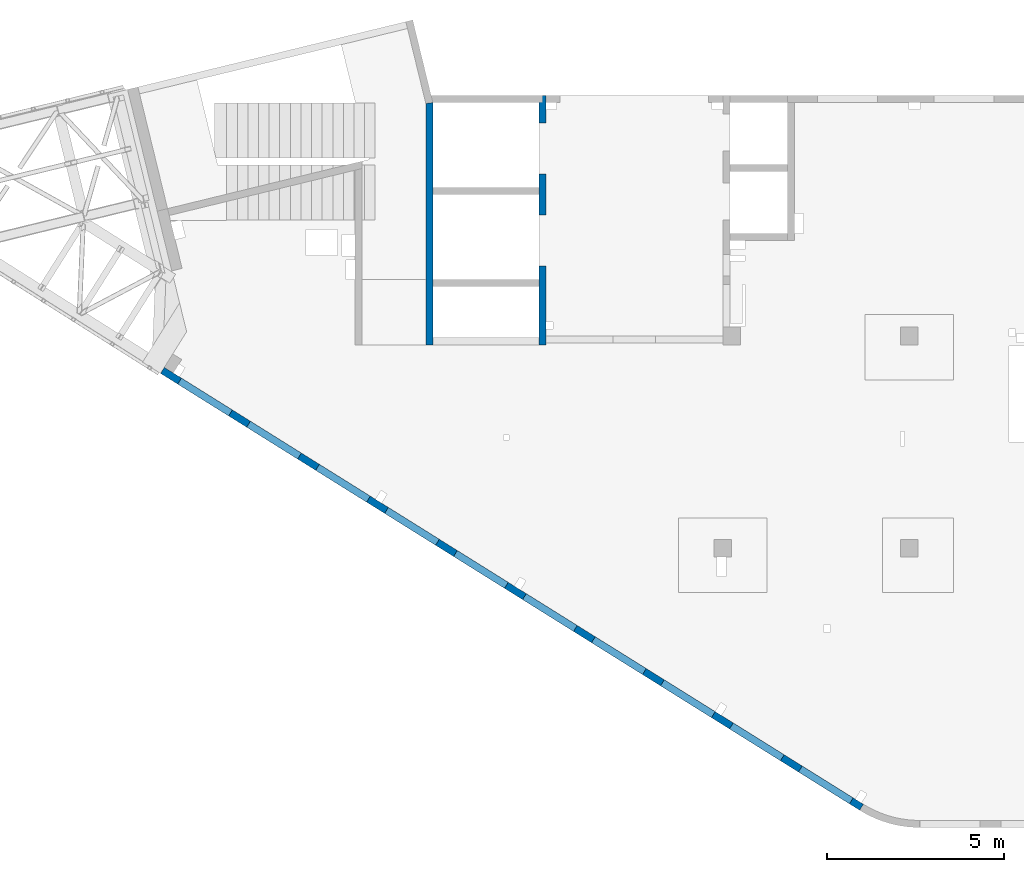
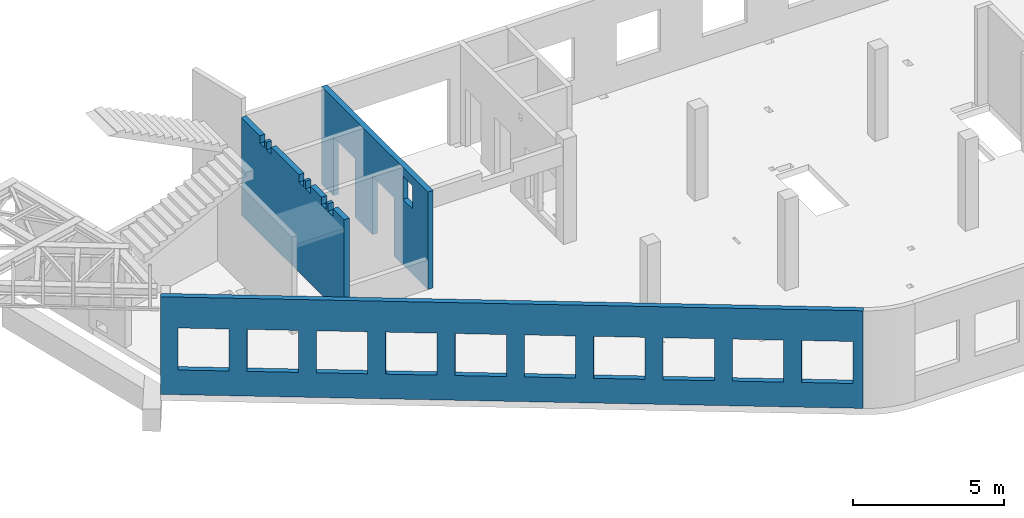
# One storey, part 64 of 66: 3 walls, 19 openings.
"""IFC4 building model written with IfcOpenShell, lengths in millimetres."""

from ifc_helpers import new_model, entity, si_unit, converted_unit, derived_unit, direction, frame, origin, place, context, subcontext, project, spatial, indexed_curve, outline, extrude, polygons, material, type_object, element, save


model = new_model("IFC4")

# Units and contexts
model_context = context("Model", 3, precision=0.01, world=origin(), true_north=direction((6.12303176911189e-17, 1.0)))
plan_context = context("Plan", 3, precision=0.01, world=origin(), true_north=direction((6.12303176911189e-17, 1.0)))
body_context = subcontext(model_context, "Body", "Model", "MODEL_VIEW")
ifc_project = project(units=[si_unit("LENGTHUNIT", "METRE", prefix="MILLI"), si_unit("AREAUNIT", "SQUARE_METRE"), si_unit("VOLUMEUNIT", "CUBIC_METRE"), converted_unit("PLANEANGLEUNIT", "DEGREE", entity("IfcRatioMeasure", 0.0174532925199433), si_unit("PLANEANGLEUNIT", "RADIAN"), dimensions=[0, 0, 0, 0, 0, 0, 0]), si_unit("MASSUNIT", "GRAM", prefix="KILO"), derived_unit("MASSDENSITYUNIT", [(si_unit("MASSUNIT", "GRAM", prefix="KILO"), 1), (si_unit("LENGTHUNIT", "METRE"), -3)]), derived_unit("MOMENTOFINERTIAUNIT", [(si_unit("LENGTHUNIT", "METRE"), 4)]), si_unit("TIMEUNIT", "SECOND"), si_unit("FREQUENCYUNIT", "HERTZ"), si_unit("THERMODYNAMICTEMPERATUREUNIT", "DEGREE_CELSIUS"), derived_unit("THERMALTRANSMITTANCEUNIT", [(si_unit("MASSUNIT", "GRAM", prefix="KILO"), 1), (si_unit("THERMODYNAMICTEMPERATUREUNIT", "KELVIN"), -1), (si_unit("TIMEUNIT", "SECOND"), -3)]), derived_unit("VOLUMETRICFLOWRATEUNIT", [(si_unit("LENGTHUNIT", "METRE"), 3), (si_unit("TIMEUNIT", "SECOND"), -1)]), derived_unit("MASSFLOWRATEUNIT", [(si_unit("MASSUNIT", "GRAM", prefix="KILO"), 1), (si_unit("TIMEUNIT", "SECOND"), -1)]), derived_unit("ROTATIONALFREQUENCYUNIT", [(si_unit("TIMEUNIT", "SECOND"), -1)]), si_unit("ELECTRICCURRENTUNIT", "AMPERE"), si_unit("ELECTRICVOLTAGEUNIT", "VOLT"), si_unit("POWERUNIT", "WATT"), si_unit("FORCEUNIT", "NEWTON", prefix="KILO"), si_unit("ILLUMINANCEUNIT", "LUX"), si_unit("LUMINOUSFLUXUNIT", "LUMEN"), si_unit("LUMINOUSINTENSITYUNIT", "CANDELA"), derived_unit("USERDEFINED", [(si_unit("MASSUNIT", "GRAM", prefix="KILO"), -1), (si_unit("LENGTHUNIT", "METRE"), -2), (si_unit("TIMEUNIT", "SECOND"), 3), (si_unit("LUMINOUSFLUXUNIT", "LUMEN"), 1)]), derived_unit("LINEARVELOCITYUNIT", [(si_unit("LENGTHUNIT", "METRE"), 1), (si_unit("TIMEUNIT", "SECOND"), -1)]), si_unit("PRESSUREUNIT", "PASCAL"), derived_unit("USERDEFINED", [(si_unit("LENGTHUNIT", "METRE"), -2), (si_unit("MASSUNIT", "GRAM", prefix="KILO"), 1), (si_unit("TIMEUNIT", "SECOND"), -2)]), derived_unit("LINEARFORCEUNIT", [(si_unit("MASSUNIT", "GRAM", prefix="KILO"), 1), (si_unit("LENGTHUNIT", "METRE"), 1), (si_unit("TIMEUNIT", "SECOND"), -2), (si_unit("LENGTHUNIT", "METRE"), -1)]), derived_unit("PLANARFORCEUNIT", [(si_unit("MASSUNIT", "GRAM", prefix="KILO"), 1), (si_unit("LENGTHUNIT", "METRE"), 1), (si_unit("TIMEUNIT", "SECOND"), -2), (si_unit("LENGTHUNIT", "METRE"), -2)])], contexts=[model_context, plan_context])

# Site, building, storey
site_placement = place(None, origin())
site = spatial("IfcSite", under=ifc_project, at=site_placement, CompositionType="ELEMENT")
building_placement = place(site_placement, origin())
building = spatial("IfcBuilding", under=site, at=building_placement, CompositionType="ELEMENT")
storey_placement = place(building_placement, frame((0.0, 0.0, 19800.0)))
storey = spatial("IfcBuildingStorey", under=building, at=storey_placement, Name="06", CompositionType="ELEMENT", Elevation=19800.0)

# Wall, openings
ifc_material = material()
wall_type = type_object("IfcWallType", Name=":ADSK_ 25_200", PredefinedType="STANDARD")
wall_1_placement = place(storey_placement, frame((19822.35, 371.16, -150.0), z_axis=(0.0, 0.0, 1.0), x_axis=(-0.848052743777574, 0.529911826412025, 0.0)))
wall_1 = element("IfcWall", 1, at=wall_1_placement, inside=storey, type_object=wall_type, material=ifc_material, Name=":ADSK_ 25_200", ObjectType=":ADSK_ 25_200", PredefinedType="NOTDEFINED", context=body_context, shape_type="Tessellation", body=[
    polygons([(9.13669140345519e-13, -100.0, 0.0), (23011.6394501553, -99.9999999999989, 0.0), (23311.6394501553, -100.000000000001, 0.0), (23311.6394501553, -100.000000000001, 3950.0), (23011.6394501553, -99.9999999999989, 3950.0), (9.13669140345519e-13, -100.0, 3950.0), (21041.6390317217, -100.0, 2700.0), (22741.6390317217, -99.9999999999989, 2700.0), (22741.6390317217, -99.9999999999989, 1000.00000000001), (21041.6390317217, -100.0, 1000.00000000001), (18741.6390317217, -99.9999999999989, 2700.0), (20441.6390317217, -100.000000000001, 2700.0), (20441.6390317217, -100.000000000001, 1000.00000000001), (18741.6390317217, -99.9999999999989, 1000.00000000001), (16441.6390317217, -100.000000000001, 2700.0), (18141.6390317217, -100.000000000001, 2700.0), (18141.6390317217, -100.000000000001, 1000.00000000001), (16441.6390317217, -100.000000000001, 1000.00000000001), (14141.6390317217, -100.0, 2700.0), (15841.6390317217, -100.0, 2700.0), (15841.6390317217, -100.0, 1000.00000000001), (14141.6390317217, -100.0, 1000.00000000001), (11841.6390317217, -99.9999999999989, 2700.0), (13541.6390317217, -100.000000000001, 2700.0), (13541.6390317217, -100.000000000001, 1000.00000000001), (11841.6390317217, -99.9999999999989, 1000.00000000001), (9541.63903172168, -100.000000000001, 2700.0), (11241.6390317217, -100.0, 2700.0), (11241.6390317217, -100.0, 1000.00000000001), (9541.63903172168, -100.000000000001, 1000.00000000001), (7241.63903172167, -99.9999999999995, 2700.0), (8941.63903172167, -99.9999999999995, 2700.0), (8941.63903172167, -99.9999999999995, 1000.00000000001), (7241.63903172167, -99.9999999999995, 1000.00000000001), (4941.63903172166, -99.9999999999989, 2700.0), (6641.63903172166, -99.9999999999989, 2700.0), (6641.63903172166, -99.9999999999989, 1000.00000000001), (4941.63903172166, -99.9999999999989, 1000.00000000001), (2641.63903172165, -100.0, 2700.0), (4341.63903172165, -100.0, 2700.0), (4341.63903172165, -100.0, 1000.00000000001), (2641.63903172165, -100.0, 1000.00000000001), (341.639031721648, -100.000000000002, 2700.0), (2041.63903172165, -100.0, 2700.0), (2041.63903172165, -100.0, 1000.00000000001), (341.639031721648, -100.000000000002, 1000.00000000001), (22741.6390317217, 100.000000000319, 2700.0), (21041.6390317217, 100.000000000321, 2700.0), (21041.6390317217, 100.000000000321, 1000.00000000001), (22741.6390317217, 100.000000000319, 1000.00000000001), (20441.6390317217, 100.000000000319, 2700.0), (18741.6390317217, 100.000000000322, 2700.0), (18741.6390317217, 100.000000000322, 1000.00000000001), (20441.6390317217, 100.000000000319, 1000.00000000001), (18141.6390317217, 100.000000000318, 2700.0), (16441.6390317217, 100.000000000319, 2700.0), (16441.6390317217, 100.000000000319, 1000.00000000001), (18141.6390317217, 100.000000000318, 1000.00000000001), (15841.6390317217, 100.000000000321, 2700.0), (14141.6390317217, 100.000000000322, 2700.0), (14141.6390317217, 100.000000000322, 1000.00000000001), (15841.6390317217, 100.000000000321, 1000.00000000001), (13541.6390317217, 100.000000000319, 2700.0), (11841.6390317217, 100.000000000321, 2700.0), (11841.6390317217, 100.000000000321, 1000.00000000001), (13541.6390317217, 100.000000000319, 1000.00000000001), (11241.6390317217, 100.000000000321, 2700.0), (9541.63903172168, 100.000000000319, 2700.0), (9541.63903172168, 100.000000000319, 1000.00000000001), (11241.6390317217, 100.000000000321, 1000.00000000001), (8941.63903172167, 100.000000000319, 2700.0), (7241.63903172167, 100.000000000321, 2700.0), (7241.63903172167, 100.000000000321, 1000.00000000001), (8941.63903172167, 100.000000000319, 1000.00000000001), (6641.63903172167, 100.000000000322, 2700.0), (4941.63903172166, 100.000000000322, 2700.0), (4941.63903172166, 100.000000000322, 1000.00000000001), (6641.63903172166, 100.000000000322, 1000.00000000001), (4341.63903172166, 100.000000000321, 2700.0), (2641.63903172165, 100.000000000319, 2700.0), (2641.63903172165, 100.000000000319, 1000.00000000001), (4341.63903172166, 100.000000000321, 1000.00000000001), (2041.63903172165, 100.000000000321, 2700.0), (341.639031721653, 100.000000000321, 2700.0), (341.639031721653, 100.00000000032, 1000.00000000001), (2041.63903172165, 100.000000000321, 1000.00000000001), (1.18438592267012e-13, 100.000000000001, 0.0), (1.18438592267012e-13, 100.000000000001, 3950.0), (23311.6394501553, 100.000000000001, 3950.0), (23311.6394501553, 100.000000000001, 0.0)], [[[1, 2, 3, 4, 5, 6], [7, 8, 9, 10], [11, 12, 13, 14], [15, 16, 17, 18], [19, 20, 21, 22], [23, 24, 25, 26], [27, 28, 29, 30], [31, 32, 33, 34], [35, 36, 37, 38], [39, 40, 41, 42], [43, 44, 45, 46]], [[87, 88, 89, 90], [47, 48, 49, 50], [51, 52, 53, 54], [55, 56, 57, 58], [59, 60, 61, 62], [63, 64, 65, 66], [67, 68, 69, 70], [71, 72, 73, 74], [75, 76, 77, 78], [79, 80, 81, 82], [83, 84, 85, 86]], [[3, 2, 1, 87, 90]], [[6, 5, 4, 89, 88]], [[1, 6, 88, 87]], [[4, 3, 90, 89]], [[48, 47, 8, 7]], [[48, 7, 10, 49]], [[49, 10, 9, 50]], [[8, 47, 50, 9]], [[52, 51, 12, 11]], [[52, 11, 14, 53]], [[53, 14, 13, 54]], [[12, 51, 54, 13]], [[56, 55, 16, 15]], [[56, 15, 18, 57]], [[57, 18, 17, 58]], [[16, 55, 58, 17]], [[60, 59, 20, 19]], [[60, 19, 22, 61]], [[61, 22, 21, 62]], [[20, 59, 62, 21]], [[64, 63, 24, 23]], [[64, 23, 26, 65]], [[65, 26, 25, 66]], [[24, 63, 66, 25]], [[68, 67, 28, 27]], [[68, 27, 30, 69]], [[69, 30, 29, 70]], [[28, 67, 70, 29]], [[72, 71, 32, 31]], [[72, 31, 34, 73]], [[73, 34, 33, 74]], [[32, 71, 74, 33]], [[76, 75, 36, 35]], [[76, 35, 38, 77]], [[77, 38, 37, 78]], [[36, 75, 78, 37]], [[80, 79, 40, 39]], [[80, 39, 42, 81]], [[81, 42, 41, 82]], [[40, 79, 82, 41]], [[84, 83, 44, 43]], [[84, 43, 46, 85]], [[85, 46, 45, 86]], [[44, 83, 86, 45]]], closed=True),
])
placement_1 = place(wall_1_placement, frame((16613.72, 10818.86, 150.0), z_axis=(0.0, 0.0, 1.0), x_axis=(-0.848052743777574, -0.529911826412026, 0.0)))
element("IfcOpeningElement", 2, at=placement_1, cuts=wall_1, Name=":ADSK_ 25_200", PredefinedType="OPENING", context=body_context, shape_type="SweptSolid", body=[
    extrude(outline(indexed_curve([(-849.999999999993, -850.0), (849.999999999993, -850.0), (849.999999999993, 850.0), (-849.999999999993, 850.0), (-849.999999999993, -850.0)], self_intersect=False)), frame((1310.08, 12056.6, 1700.0), z_axis=(-0.529911826412026, -0.848052743777574, 0.0), x_axis=(0.0, 0.0, -1.0)), (0.0, 0.0, 1.0), 200.000000000959),
])
element("IfcOpeningElement", 3, at=placement_1, cuts=wall_1, Name=":ADSK_ 25_200", PredefinedType="OPENING", context=body_context, shape_type="SweptSolid", body=[
    extrude(outline(indexed_curve([(-849.999999999993, -850.0), (849.999999999993, -850.0), (849.999999999993, 850.0), (-849.999999999993, 850.0), (-849.999999999993, -850.0)], self_intersect=False)), frame((3260.6, 10837.81, 1700.0), z_axis=(-0.529911826412026, -0.848052743777574, 0.0), x_axis=(0.0, 0.0, -1.0)), (0.0, 0.0, 1.0), 200.000000000962),
])
element("IfcOpeningElement", 4, at=placement_1, cuts=wall_1, Name=":ADSK_ 25_200", PredefinedType="OPENING", context=body_context, shape_type="SweptSolid", body=[
    extrude(outline(indexed_curve([(-849.999999999993, -849.999999999999), (849.999999999993, -849.999999999999), (849.999999999993, 850.0), (-849.999999999993, 850.0), (-849.999999999993, -849.999999999999)], self_intersect=False)), frame((5211.12, 9619.01, 1700.0), z_axis=(-0.529911826412025, -0.848052743777574, 0.0), x_axis=(0.0, 0.0, -1.0)), (0.0, 0.0, 1.0), 200.000000000962),
])
element("IfcOpeningElement", 5, at=placement_1, cuts=wall_1, Name=":ADSK_ 25_200", PredefinedType="OPENING", context=body_context, shape_type="SweptSolid", body=[
    extrude(outline(indexed_curve([(-849.999999999993, -849.999999999999), (849.999999999993, -849.999999999999), (849.999999999993, 850.0), (-849.999999999993, 850.0), (-849.999999999993, -849.999999999999)], self_intersect=False)), frame((7161.64, 8400.21, 1700.0), z_axis=(-0.529911826412026, -0.848052743777574, 0.0), x_axis=(0.0, 0.0, -1.0)), (0.0, 0.0, 1.0), 200.000000000962),
])
element("IfcOpeningElement", 6, at=placement_1, cuts=wall_1, Name=":ADSK_ 25_200", PredefinedType="OPENING", context=body_context, shape_type="SweptSolid", body=[
    extrude(outline(indexed_curve([(-849.999999999993, -849.999999999999), (849.999999999993, -849.999999999999), (849.999999999993, 850.0), (-849.999999999993, 850.0), (-849.999999999993, -849.999999999999)], self_intersect=False)), frame((9112.16, 7181.41, 1700.0), z_axis=(-0.529911826412026, -0.848052743777574, 0.0), x_axis=(0.0, 0.0, -1.0)), (0.0, 0.0, 1.0), 200.000000000959),
])
element("IfcOpeningElement", 7, at=placement_1, cuts=wall_1, Name=":ADSK_ 25_200", PredefinedType="OPENING", context=body_context, shape_type="SweptSolid", body=[
    extrude(outline(indexed_curve([(-849.999999999993, -850.0), (849.999999999993, -850.0), (849.999999999993, 850.0), (-849.999999999993, 850.0), (-849.999999999993, -850.0)], self_intersect=False)), frame((11062.68, 5962.62, 1700.0), z_axis=(-0.529911826412025, -0.848052743777574, 0.0), x_axis=(0.0, 0.0, -1.0)), (0.0, 0.0, 1.0), 200.000000000964),
])
element("IfcOpeningElement", 8, at=placement_1, cuts=wall_1, Name=":ADSK_ 25_200", PredefinedType="OPENING", context=body_context, shape_type="SweptSolid", body=[
    extrude(outline(indexed_curve([(-849.999999999993, -850.0), (849.999999999993, -850.0), (849.999999999993, 850.0), (-849.999999999993, 850.0), (-849.999999999993, -850.0)], self_intersect=False)), frame((13013.21, 4743.82, 1700.0), z_axis=(-0.529911826412025, -0.848052743777574, 0.0), x_axis=(0.0, 0.0, -1.0)), (0.0, 0.0, 1.0), 200.000000000962),
])
element("IfcOpeningElement", 9, at=placement_1, cuts=wall_1, Name=":ADSK_ 25_200", PredefinedType="OPENING", context=body_context, shape_type="SweptSolid", body=[
    extrude(outline(indexed_curve([(-849.999999999993, -850.000000000003), (849.999999999993, -850.000000000003), (849.999999999993, 849.999999999998), (-849.999999999993, 849.999999999998), (-849.999999999993, -850.000000000003)], self_intersect=False)), frame((14963.73, 3525.02, 1700.0), z_axis=(-0.529911826412025, -0.848052743777574, 0.0), x_axis=(0.0, 0.0, -1.0)), (0.0, 0.0, 1.0), 200.000000000962),
])
element("IfcOpeningElement", 10, at=placement_1, cuts=wall_1, Name=":ADSK_ 25_200", PredefinedType="OPENING", context=body_context, shape_type="SweptSolid", body=[
    extrude(outline(indexed_curve([(-849.999999999993, -849.999999999998), (849.999999999993, -849.999999999998), (849.999999999993, 850.000000000002), (-849.999999999993, 850.000000000002), (-849.999999999993, -849.999999999998)], self_intersect=False)), frame((16914.25, 2306.23, 1700.0), z_axis=(-0.529911826412025, -0.848052743777574, 0.0), x_axis=(0.0, 0.0, -1.0)), (0.0, 0.0, 1.0), 200.000000000962),
])
element("IfcOpeningElement", 11, at=placement_1, cuts=wall_1, Name=":ADSK_ 25_200", PredefinedType="OPENING", context=body_context, shape_type="SweptSolid", body=[
    extrude(outline(indexed_curve([(-849.999999999993, -850.0), (849.999999999993, -850.0), (849.999999999993, 850.0), (-849.999999999993, 850.0), (-849.999999999993, -850.0)], self_intersect=False)), frame((18864.77, 1087.43, 1700.0), z_axis=(-0.529911826412025, -0.848052743777574, 0.0), x_axis=(0.0, 0.0, -1.0)), (0.0, 0.0, 1.0), 200.000000000962),
])

wall_2_placement = place(storey_placement, frame((10800.0, 20500.0, -150.0), z_axis=(0.0, 0.0, 1.0), x_axis=(0.0, -1.0, 0.0)))
wall_2 = element("IfcWall", 12, at=wall_2_placement, inside=storey, type_object=wall_type, material=ifc_material, Name=":ADSK_ 25_200", ObjectType=":ADSK_ 25_200", PredefinedType="NOTDEFINED", context=body_context, shape_type="Tessellation", body=[
    polygons([(5400.00000000001, -100.0, 3600.0), (6050.00000000001, -100.000000000001, 3600.0), (6050.00000000001, -100.000000000001, 2650.00000000001), (5400.00000000001, -100.0, 2650.00000000001), (7050.00063936681, -100.000000000002, 3950.0), (6850.0006393668, -100.000000000002, 3950.0), (5400.00000000001, -100.0, 3950.0), (5200.00000000001, -100.000000000001, 3950.0), (2800.00000000001, -100.000000000001, 3950.0), (2600.00000000001, -100.000000000001, 3950.0), (200.000000000002, -100.000000000001, 3950.0), (4.33146851719357e-12, -100.000000000001, 3950.0), (4.33146851719357e-12, -100.000000000001, 49.9999999999973), (4.33146851719357e-12, -100.000000000001, 0.0), (200.000000000002, -100.000000000001, 0.0), (780.000000000005, -100.000000000002, 0.0), (780.000000000005, -100.000000000002, 2369.99999999805), (2220.0, -100.000000000002, 2369.99999999804), (2220.0, -100.000000000002, 0.0), (3380.0, -100.000000000002, 0.0), (3380.0, -100.000000000002, 2369.99999999805), (4820.0, -100.000000000001, 2369.99999999805), (4820.0, -100.000000000001, 0.0), (6850.00063936681, -100.000000000002, 0.0), (7050.00063936681, -100.000000000002, 0.0), (7050.00063936681, -100.000000000002, 1200.0), (6050.0, 100.000000000321, 3600.0), (5400.0, 100.00000000032, 3600.0), (5400.00000000001, 100.00000000032, 2650.00000000001), (6050.0, 100.000000000321, 2650.00000000001), (0.0, 99.9999999999987, 3950.0), (199.999999999998, 99.999999999999, 3950.0), (400.0, 99.9999999999994, 3950.0), (6400.00063936679, 99.9999999999994, 3950.0), (6600.00063936679, 99.9999999999998, 3950.0), (6800.00063936679, 99.999999999998, 3950.0), (7000.00063936679, 99.9999999999984, 3950.0), (7050.00063936681, 99.9999999999984, 3950.0), (7050.0006393668, 99.9999999999984, 0.0), (6600.00063936679, 99.9999999999998, 0.0), (6400.00063936679, 99.9999999999994, 0.0), (4819.99999999999, 99.9999999999987, 0.0), (4820.0, 99.9999999999987, 2369.99999999805), (3380.0, 99.9999999999983, 2369.99999999804), (3380.0, 99.9999999999983, 0.0), (2220.0, 99.9999999999984, 0.0), (2220.0, 99.9999999999984, 2369.99999999804), (780.0, 100.0, 2369.99999999805), (780.0, 99.9999999999979, 0.0), (399.999999999965, 99.9999999999994, 0.0), (199.999999999998, 99.999999999999, 0.0), (0.0, 99.9999999999987, 0.0), (0.0, -2.40817119847655e-12, 0.0)], [[[5, 6, 7, 8, 9, 10, 11, 12, 13, 14, 15, 16, 17, 18, 19, 20, 21, 22, 23, 24, 25, 26], [1, 2, 3, 4]], [[31, 32, 33, 34, 35, 36, 37, 38, 39, 40, 41, 42, 43, 44, 45, 46, 47, 48, 49, 50, 51, 52], [27, 28, 29, 30]], [[16, 15, 14, 53, 52, 51, 50, 49]], [[12, 11, 10, 9, 8, 7, 6, 5, 38, 37, 36, 35, 34, 33, 32, 31]], [[43, 22, 21, 44]], [[44, 21, 20, 45]], [[22, 43, 42, 23]], [[17, 48, 47, 18]], [[18, 47, 46, 19]], [[48, 17, 16, 49]], [[28, 27, 2, 1]], [[28, 1, 4, 29]], [[29, 4, 3, 30]], [[2, 27, 30, 3]], [[5, 26, 25, 39, 38]], [[52, 53, 14, 13, 12, 31]], [[19, 46, 45, 20]], [[39, 25, 24, 23, 42, 41, 40]]], closed=True),
])
placement_2 = place(wall_2_placement, frame((20500.0, -10800.0, 150.0), z_axis=(0.0, 0.0, 1.0), x_axis=(0.0, 1.0, 0.0)))
element("IfcOpeningElement", 13, at=placement_2, cuts=wall_2, Name=":ADSK_ 25_200", PredefinedType="OPENING", context=body_context, shape_type="SweptSolid", body=[
    extrude(outline(indexed_curve([(-719.999999999999, -1184.99999999902), (719.999999999999, -1184.99999999902), (719.999999999999, 1184.99999999902), (-719.999999999999, 1184.99999999902), (-719.999999999999, -1184.99999999902)], self_intersect=False)), frame((10600.0, 19000.0, 1035.0), z_axis=(1.0, 0.0, 0.0), x_axis=(0.0, -1.0, 0.0)), (0.0, 0.0, 1.0), 400.000000001943),
])
element("IfcOpeningElement", 14, at=placement_2, cuts=wall_2, Name=":ADSK_ 25_200", PredefinedType="OPENING", context=body_context, shape_type="SweptSolid", body=[
    extrude(outline(indexed_curve([(-1184.99999999902, -719.999999999999), (1184.99999999902, -719.999999999999), (1184.99999999902, 720.000000000001), (-1184.99999999902, 720.000000000001), (-1184.99999999902, -719.999999999999)], self_intersect=False)), frame((10600.0, 16400.0, 1035.0), z_axis=(1.0, 0.0, 0.0), x_axis=(0.0, 0.0, -1.0)), (0.0, 0.0, 1.0), 400.000000001943),
])
element("IfcOpeningElement", 15, at=placement_2, cuts=wall_2, Name=":ADSK_ 25_200", PredefinedType="OPENING", context=body_context, shape_type="SweptSolid", body=[
    extrude(outline(indexed_curve([(-474.999999999996, -325.0), (474.999999999992, -325.0), (474.999999999992, 325.0), (-474.999999999996, 325.0), (-474.999999999996, -325.0)], self_intersect=False)), frame((10700.0, 14775.0, 2975.0), z_axis=(1.0, 0.0, 0.0), x_axis=(0.0, 0.0, -1.0)), (0.0, 0.0, 1.0), 200.000000000962),
])

wall_3_placement = place(storey_placement, frame((7600.0, 20297.52, -150.0), z_axis=(0.0, 0.0, 1.0), x_axis=(0.0, -1.0, 0.0)))
wall_3 = element("IfcWall", 16, at=wall_3_placement, inside=storey, type_object=wall_type, material=ifc_material, Name=":ADSK_ 25_200", ObjectType=":ADSK_ 25_200", PredefinedType="NOTDEFINED", context=body_context, shape_type="Tessellation", body=[
    polygons([(24.0243306802226, -100.0, 0.0), (6847.52486422541, -99.9999999999992, 0.0), (6847.52486422541, -99.9999999999992, 3950.0), (6092.52422485862, -100.000000000001, 3950.0), (6092.52422485862, -100.000000000001, 3650.00000000001), (5782.52422485862, -100.0, 3650.00000000001), (5782.52422485862, -100.0, 3950.0), (5652.52422485862, -100.0, 3950.0), (5652.52422485862, -100.0, 3650.00000000001), (5342.52422485862, -100.000000000001, 3650.00000000001), (5342.52422485862, -100.000000000001, 3950.0), (4596.52422485859, -100.000000000001, 3950.0), (4596.52422485859, -100.000000000001, 3650.00000000001), (4286.52422485859, -100.000000000001, 3650.00000000001), (4286.52422485859, -100.000000000001, 3950.0), (4156.52422485859, -100.000000000002, 3950.0), (4156.52422485859, -100.000000000002, 3650.00000000001), (3846.52422485859, -100.0, 3650.00000000001), (3846.52422485859, -100.0, 3950.0), (1996.52422485859, -99.9999999999989, 3950.0), (1996.52422485859, -99.9999999999989, 3650.00000000001), (1686.52422485859, -99.9999999999994, 3650.00000000001), (1686.52422485859, -99.9999999999994, 3950.0), (1556.52422485858, -99.9999999999996, 3950.0), (1556.52422485858, -99.9999999999996, 3650.00000000001), (1246.52422485858, -100.0, 3650.00000000001), (1246.52422485858, -100.0, 3950.0), (24.0243306802226, -100.0, 3950.0), (6847.52486422541, 99.9999999999997, 0.0), (6647.52486422541, 99.9999999999993, 0.0), (0.0, 99.9999999999999, 0.0), (0.0, 99.9999999999999, 3950.0), (1246.52422485858, 99.9999999999998, 3950.0), (1246.52422485859, 100.00000000032, 3650.00000000001), (1556.52422485858, 100.00000000032, 3650.00000000001), (1556.52422485858, 99.9999999999993, 3950.0), (1686.52422485859, 99.9999999999995, 3950.0), (1686.52422485859, 100.00000000032, 3650.00000000001), (1996.52422485859, 100.000000000321, 3650.00000000001), (1996.52422485859, 100.0, 3950.0), (2397.52422485862, 99.9999999999996, 3950.0), (2597.52422485862, 100.0, 3950.0), (3846.52422485859, 100.0, 3950.0), (3846.52422485859, 100.000000000319, 3650.00000000001), (4156.52422485859, 100.00000000032, 3650.00000000001), (4156.52422485859, 99.9999999999994, 3950.0), (4286.52422485859, 99.9999999999996, 3950.0), (4286.52422485859, 100.00000000032, 3650.00000000001), (4596.52422485859, 100.000000000321, 3650.00000000001), (4596.52422485859, 100.0, 3950.0), (4997.52422485862, 99.9999999999998, 3950.0), (5197.52422485862, 100.0, 3950.0), (5342.52422485862, 99.9999999999982, 3950.0), (5342.52422485862, 100.000000000319, 3650.00000000001), (5652.52422485862, 100.000000000319, 3650.00000000001), (5652.52422485862, 99.9999999999987, 3950.0), (5782.52422485862, 99.999999999999, 3950.0), (5782.52422485862, 100.000000000319, 3650.00000000001), (6092.52422485862, 100.00000000032, 3650.00000000001), (6092.52422485862, 99.9999999999995, 3950.0), (6647.5248642254, 99.9999999999993, 3950.0), (6847.52486422541, 99.9999999999997, 3950.0), (6847.52486422541, 99.9999999999997, 1200.0)], [[[1, 2, 3, 4, 5, 6, 7, 8, 9, 10, 11, 12, 13, 14, 15, 16, 17, 18, 19, 20, 21, 22, 23, 24, 25, 26, 27, 28]], [[29, 30, 31, 32, 33, 34, 35, 36, 37, 38, 39, 40, 41, 42, 43, 44, 45, 46, 47, 48, 49, 50, 51, 52, 53, 54, 55, 56, 57, 58, 59, 60, 61, 62, 63]], [[2, 1, 31, 30, 29]], [[4, 3, 62, 61, 60]], [[10, 54, 53, 11]], [[54, 10, 9, 55]], [[55, 9, 8, 56]], [[6, 58, 57, 7]], [[58, 6, 5, 59]], [[59, 5, 4, 60]], [[3, 2, 29, 63, 62]], [[14, 48, 47, 15]], [[48, 14, 13, 49]], [[49, 13, 12, 50]], [[18, 44, 43, 19]], [[44, 18, 17, 45]], [[45, 17, 16, 46]], [[22, 38, 37, 23]], [[38, 22, 21, 39]], [[39, 21, 20, 40]], [[26, 34, 33, 27]], [[34, 26, 25, 35]], [[35, 25, 24, 36]], [[1, 28, 32, 31]], [[11, 53, 52, 51, 50, 12]], [[15, 47, 46, 16]], [[19, 43, 42, 41, 40, 20]], [[23, 37, 36, 24]], [[56, 8, 7, 57]], [[32, 28, 27, 33]]], closed=True),
])
placement_3 = place(wall_3_placement, frame((20297.52, -7600.0, 150.0), z_axis=(0.0, 0.0, 1.0), x_axis=(0.0, 1.0, 0.0)))
element("IfcOpeningElement", 17, at=placement_3, cuts=wall_3, Name=":ADSK_ 25_200", PredefinedType="OPENING", context=body_context, shape_type="SweptSolid", body=[
    extrude(outline(indexed_curve([(-154.999999999995, -154.999999999999), (154.999999999991, -154.999999999999), (154.999999999991, 154.999999999999), (-154.999999999995, 154.999999999999), (-154.999999999995, -154.999999999999)], self_intersect=False)), frame((7500.0, 14800.0, 3655.0), z_axis=(1.0, 0.0, 0.0), x_axis=(0.0, 0.0, -1.0)), (0.0, 0.0, 1.0), 200.000000000962),
])
element("IfcOpeningElement", 18, at=placement_3, cuts=wall_3, Name=":ADSK_ 25_200", PredefinedType="OPENING", context=body_context, shape_type="SweptSolid", body=[
    extrude(outline(indexed_curve([(-154.999999999995, -154.999999999999), (154.999999999991, -154.999999999999), (154.999999999991, 154.999999999999), (-154.999999999995, 154.999999999999), (-154.999999999995, -154.999999999999)], self_intersect=False)), frame((7500.0, 14360.0, 3655.0), z_axis=(1.0, 0.0, 0.0), x_axis=(0.0, 0.0, -1.0)), (0.0, 0.0, 1.0), 200.000000000962),
])
element("IfcOpeningElement", 19, at=placement_3, cuts=wall_3, Name=":ADSK_ 25_200", PredefinedType="OPENING", context=body_context, shape_type="SweptSolid", body=[
    extrude(outline(indexed_curve([(-154.999999999995, -154.999999999999), (154.999999999991, -154.999999999999), (154.999999999991, 154.999999999999), (-154.999999999995, 154.999999999999), (-154.999999999995, -154.999999999999)], self_intersect=False)), frame((7500.0, 15856.0, 3655.0), z_axis=(1.0, 0.0, 0.0), x_axis=(0.0, 0.0, -1.0)), (0.0, 0.0, 1.0), 200.000000000962),
])
element("IfcOpeningElement", 20, at=placement_3, cuts=wall_3, Name=":ADSK_ 25_200", PredefinedType="OPENING", context=body_context, shape_type="SweptSolid", body=[
    extrude(outline(indexed_curve([(-154.999999999995, -154.999999999999), (154.999999999991, -154.999999999999), (154.999999999991, 154.999999999999), (-154.999999999995, 154.999999999999), (-154.999999999995, -154.999999999999)], self_intersect=False)), frame((7500.0, 16296.0, 3655.0), z_axis=(1.0, 0.0, 0.0), x_axis=(0.0, 0.0, -1.0)), (0.0, 0.0, 1.0), 200.000000000962),
])
element("IfcOpeningElement", 21, at=placement_3, cuts=wall_3, Name=":ADSK_ 25_200", PredefinedType="OPENING", context=body_context, shape_type="SweptSolid", body=[
    extrude(outline(indexed_curve([(-154.999999999995, -154.999999999999), (154.999999999991, -154.999999999999), (154.999999999991, 154.999999999999), (-154.999999999995, 154.999999999999), (-154.999999999995, -154.999999999999)], self_intersect=False)), frame((7500.0, 18456.0, 3655.0), z_axis=(1.0, 0.0, 0.0), x_axis=(0.0, 0.0, -1.0)), (0.0, 0.0, 1.0), 200.000000000962),
])
element("IfcOpeningElement", 22, at=placement_3, cuts=wall_3, Name=":ADSK_ 25_200", PredefinedType="OPENING", context=body_context, shape_type="SweptSolid", body=[
    extrude(outline(indexed_curve([(-154.999999999995, -154.999999999999), (154.999999999991, -154.999999999999), (154.999999999991, 154.999999999999), (-154.999999999995, 154.999999999999), (-154.999999999995, -154.999999999999)], self_intersect=False)), frame((7500.0, 18896.0, 3655.0), z_axis=(1.0, 0.0, 0.0), x_axis=(0.0, 0.0, -1.0)), (0.0, 0.0, 1.0), 200.000000000962),
])

save(model, "model.ifc")
